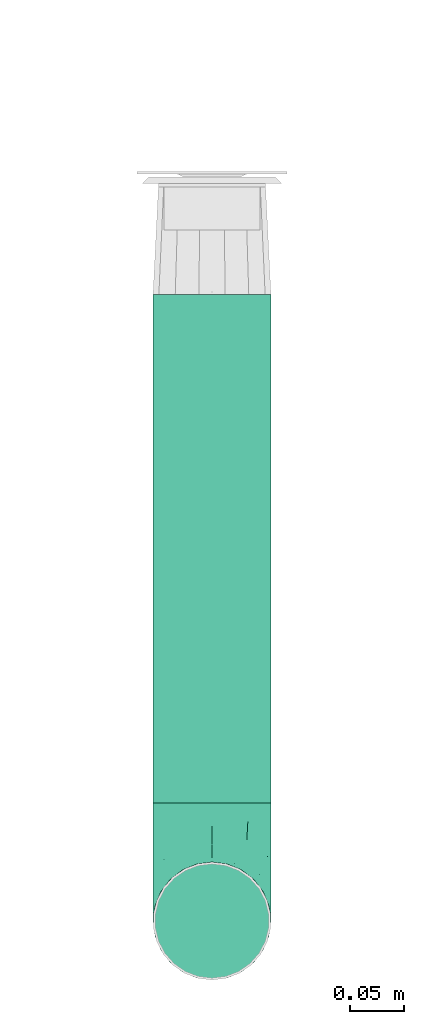
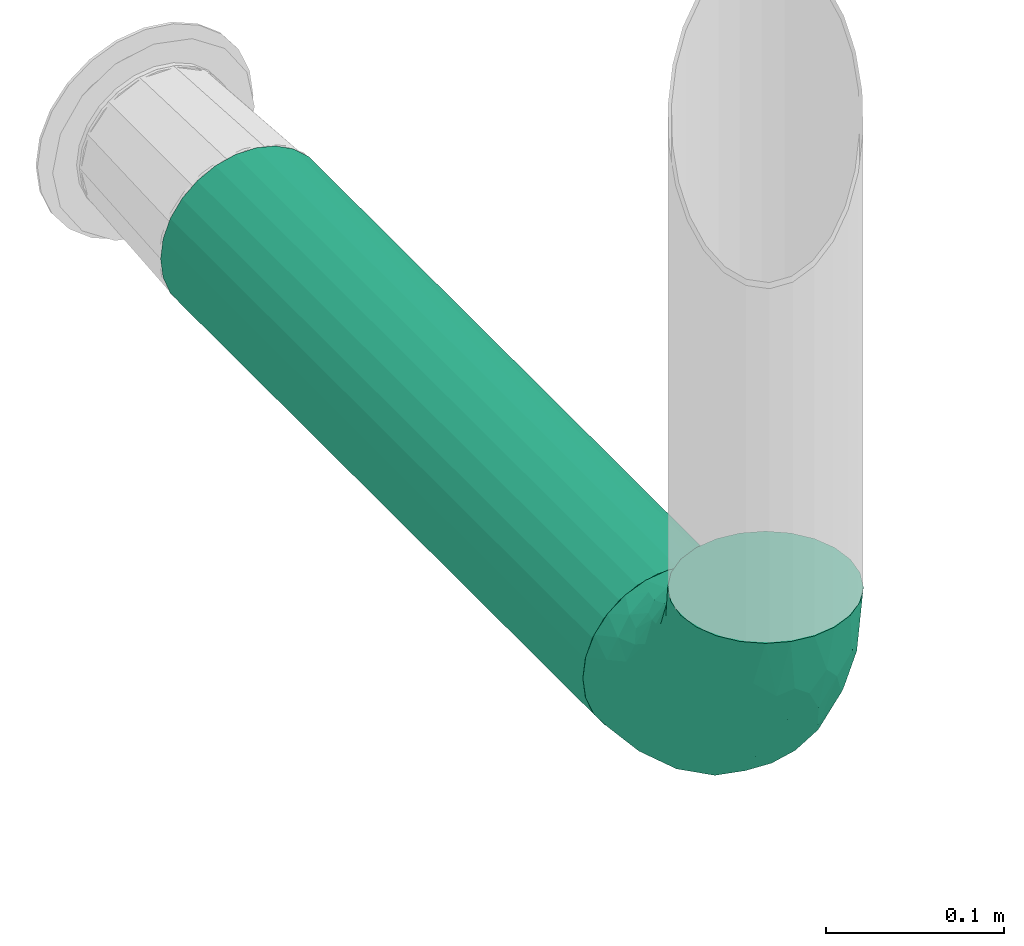
# One storey, part 56 of 115: 1 flow fitting, 1 flow segment.
"""IFC2X3 building model written with IfcOpenShell, lengths in millimetres."""

from ifc_helpers import new_model, entity, si_unit, converted_unit, derived_unit, direction, frame, origin_with_axes, origin_2d_with_axis, place, context, subcontext, project, spatial, hollow_circle, extrude, open_shell, surface_model, source, transform, mapped, material, layer, layer_set, layer_usage, type_object, element, save


model = new_model("IFC2X3")

# Units and contexts
model_context = context("Model", 3, precision=1e-05, world=origin_with_axes(), true_north=direction((0.0, 1.0)))
body_context = subcontext(model_context, "Body", "Model", "MODEL_VIEW")
ifc_project = project(units=[si_unit("AREAUNIT", "SQUARE_METRE"), si_unit("VOLUMEUNIT", "CUBIC_METRE", prefix="DECI"), si_unit("TIMEUNIT", "SECOND"), si_unit("THERMODYNAMICTEMPERATUREUNIT", "DEGREE_CELSIUS"), si_unit("PRESSUREUNIT", "PASCAL"), si_unit("MASSUNIT", "GRAM", prefix="KILO"), si_unit("LENGTHUNIT", "METRE", prefix="MILLI"), si_unit("POWERUNIT", "WATT"), si_unit("ELECTRICCURRENTUNIT", "AMPERE"), si_unit("ELECTRICVOLTAGEUNIT", "VOLT"), derived_unit("VOLUMETRICFLOWRATEUNIT", [(si_unit("VOLUMEUNIT", "CUBIC_METRE", prefix="DECI"), 1), (si_unit("TIMEUNIT", "SECOND"), -1)]), derived_unit("LINEARVELOCITYUNIT", [(si_unit("LENGTHUNIT", "METRE"), 1), (si_unit("TIMEUNIT", "SECOND"), -1)]), derived_unit("MASSDENSITYUNIT", [(si_unit("MASSUNIT", "GRAM", prefix="KILO"), 1), (si_unit("VOLUMEUNIT", "CUBIC_METRE"), -1)]), converted_unit("PLANEANGLEUNIT", "DEGREE", entity("IfcRatioMeasure", 0.01745), si_unit("PLANEANGLEUNIT", "RADIAN"), dimensions=[0, 0, 0, 0, 0, 0, 0])], contexts=[model_context])

# Site, building, storey
site_placement = place(None, origin_with_axes())
site = spatial("IfcSite", under=ifc_project, at=site_placement, CompositionType="ELEMENT")
building_placement = place(site_placement, origin_with_axes())
building = spatial("IfcBuilding", under=site, at=building_placement, Name="mc-building", CompositionType="ELEMENT")
storey_placement = place(building_placement, frame((0.0, 0.0, 2950.0), z_axis=(0.0, 0.0, 1.0), x_axis=(1.0, 0.0, 0.0)))
storey = spatial("IfcBuildingStorey", under=building, at=storey_placement, Name="2. Korrus", CompositionType="ELEMENT", Elevation=2950.0)

# Flow fitting
duct_fitting_type = type_object("IfcDuctFittingType", Name="BU", PredefinedType="BEND")
shared_shape_1 = source(origin_with_axes(), body_context, "Body", "SurfaceModel", [
    surface_model("IfcShellBasedSurfaceModel", [(-110.0, -38.89087, -38.89087), (-110.0, -55.0, 0.0), (-110.0, -27.5, -47.63139), (-110.0, -53.12592, -14.23505), (-110.0, -47.63139, -27.5), (-110.0, 47.63139, -27.5), (-110.0, 53.12592, 14.23505), (-110.0, 53.12592, -14.23505), (-110.0, -14.23505, -53.12592), (-110.0, 0.0, -55.0), (-110.0, 38.89087, -38.89087), (-110.0, 27.5, -47.63139), (-110.0, 14.23505, -53.12592), (-110.0, 55.0, 0.0), (-110.0, -53.12592, 14.23505), (-110.0, -47.63139, 27.5), (-110.0, -38.89087, 38.89087), (-110.0, 0.0, 55.0), (-110.0, -27.5, 47.63139), (-110.0, -14.23505, 53.12592), (-110.0, 38.89087, 38.89087), (-110.0, 47.63139, 27.5), (-110.0, 27.5, 47.63139), (-110.0, 14.23505, 53.12592), (0.0, -110.0, -55.0), (14.23505, -110.0, -53.12592), (-14.23505, -110.0, -53.12592), (-53.12592, -110.0, 14.23505), (-27.5, -110.0, -47.63139), (-47.63139, -110.0, -27.5), (-38.89087, -110.0, -38.89087), (55.0, -110.0, 0.0), (53.12592, -110.0, 14.23505), (38.89087, -110.0, -38.89087), (27.5, -110.0, -47.63139), (53.12592, -110.0, -14.23505), (47.63139, -110.0, -27.5), (-53.12592, -110.0, -14.23505), (-47.63139, -110.0, 27.5), (-38.89087, -110.0, 38.89087), (14.23505, -110.0, 53.12592), (-27.5, -110.0, 47.63139), (-14.23505, -110.0, 53.12592), (47.63139, -110.0, 27.5), (38.89087, -110.0, 38.89087), (27.5, -110.0, 47.63139), (0.0, -110.0, 55.0), (-55.0, -110.0, 0.0), (-60.44912, -32.56953, 51.94617), (-76.6405, -38.18013, 45.55988), (-64.21732, -48.68956, 43.63444), (-90.15553, -11.94394, 54.09138), (-76.00813, -5.38378, 55.0), (-70.18771, -18.55163, 54.03432), (-78.5998, -26.77405, 50.81338), (-93.27622, -45.77614, 33.48188), (-75.55424, -54.2118, 32.41257), (-96.12334, -22.13664, 50.81337), (-32.04182, -59.64019, 52.24446), (-18.36258, -70.48427, 54.04484), (-21.00813, -45.34362, 55.0), (-63.60674, -66.07878, 29.97482), (-74.66383, -63.08407, 19.92123), (-63.88653, -74.77858, 17.99134), (-93.11138, -56.59448, 10.50359), (-99.597, -52.72185, 18.52927), (-98.21577, -57.34403, 0.0), (-53.42855, -92.60092, 21.04759), (-88.54852, -54.8376, 21.04759), (-5.38378, -76.00813, 55.0), (-11.86161, -90.23965, 54.10313), (-56.64619, -93.12774, 10.22088), (-57.34403, -98.21577, 0.0), (-44.60838, -44.60838, 52.13415), (-45.34362, -21.00813, 55.0), (-92.68484, -35.46673, 43.63443), (-22.25266, -95.40765, 50.81337), (-27.23711, -77.39884, 50.81337), (-43.70931, -69.58671, 44.47149), (-35.97783, -90.61597, 43.63443), (-58.67786, -84.31125, 16.04456), (-57.2828, -79.3123, 24.9774), (-82.93277, -60.36161, 12.91784), (-49.88337, -54.51816, 47.224), (-74.57753, -66.83759, 9.55742), (-45.35812, -94.97281, 33.48188), (-59.18663, -88.95241, 0.0), (-51.517, -78.6292, 33.48188), (-65.14788, -80.03077, 0.0), (-56.45322, -62.06476, 39.63545), (-88.95241, -59.18663, 0.0), (-80.03077, -65.14788, 0.0), (-71.10913, -71.10913, 0.0), (-94.9309, -45.36788, -33.48188), (-93.11358, -56.60141, -10.46614), (-99.64997, -52.79499, -18.30015), (-79.99933, -46.56772, -37.92748), (-90.20425, -36.08686, -43.63443), (-45.34362, -21.00813, -55.0), (-72.75364, -19.68651, -53.60527), (-76.00813, -5.38378, -55.0), (-21.00813, -45.34362, -55.0), (-5.38378, -76.00813, -55.0), (-21.91957, -65.12078, -53.85897), (-35.41876, -92.89265, -43.63443), (-91.10309, -11.02766, -54.21832), (-45.77614, -93.27622, -33.48188), (-90.50474, -23.21022, -50.81337), (-70.92854, -33.31794, -49.51754), (-78.52933, -63.35627, -11.73997), (-24.91508, -84.05606, -50.81337), (-88.78941, -54.74452, -21.04759), (-63.49062, -67.59111, -28.46929), (-73.36422, -62.46673, -22.94182), (-69.59921, -57.34866, -33.48187), (-56.59448, -93.11138, -10.50359), (-54.10679, -75.85581, -32.31867), (-54.8376, -88.54852, -21.04759), (-57.75956, -31.09612, -52.80882), (-52.72185, -99.597, -18.52927), (-12.62913, -89.46304, -53.99097), (-34.46825, -66.46123, -50.04329), (-43.9837, -43.9837, -52.42279), (-65.78527, -72.58348, -17.68796), (-57.47001, -51.99467, -44.91465), (-70.34468, -43.65295, -44.21951), (-60.72547, -82.29174, -12.88567), (-42.34915, -74.24548, -43.63444), (-57.25194, -63.5016, -38.08211), (-80.95344, -53.56991, -29.32027), (-52.32891, -4.55257, -54.0482), (14.95561, -36.05775, -42.26543), (14.88266, -20.92917, -33.7947), (32.52942, -47.13398, -30.48571), (19.3559, -65.35825, -48.00507), (30.24048, -70.09027, -41.7461), (-28.49299, 30.5778, -16.4009), (-47.13398, 32.52942, -30.48571), (-70.35075, 46.44478, -19.5952), (-22.4954, -22.4954, -53.25347), (-4.55257, -52.32891, -54.0482), (-75.47368, 11.22546, -52.60718), (-81.32209, 51.5606, -9.98467), (-70.09027, 30.24048, -41.7461), (-80.81763, 41.84862, -32.14655), (-9.15831, 10.852, -27.8997), (-36.05774, 14.95561, -42.26543), (-65.35825, 19.3559, -48.00507), (3.94376, -43.9333, -50.53315), (11.22546, -75.47368, -52.60718), (-43.9333, 3.94376, -50.53315), (-13.39742, -13.39743, -48.13058), (50.20582, -74.51695, -9.9731), (41.8609, -47.82256, -9.92641), (49.37776, -67.29486, 0.0), (18.93131, -11.7156, -17.56239), (-1.23348, 12.25375, -12.18106), (-27.5, 32.89419, 0.0), (41.84862, -80.81763, -32.14655), (46.44478, -70.35075, -19.5952), (35.70604, -41.31408, -20.38235), (6.67262, 6.67262, 0.0), (32.89419, -27.5, 0.0), (-50.36265, 42.95545, -9.51562), (-67.29486, 49.37776, 0.0), (-5.47251, -5.47251, -39.92906), (-70.35075, 46.44478, 19.5952), (-74.51695, 50.20582, 9.9731), (-47.13398, 32.52942, 30.48571), (-41.31407, 35.70604, 20.38235), (-80.81763, 41.84862, 32.14655), (11.22546, -75.47368, 52.60718), (-4.55257, -52.32891, 54.0482), (-36.05774, 14.95561, 42.26543), (-65.35825, 19.3559, 48.00507), (-43.9333, 3.94376, 50.53315), (-70.09027, 30.24048, 41.7461), (-11.7156, 18.93131, 17.56239), (12.25375, -1.23348, 12.18106), (30.5778, -28.49299, 16.4009), (42.95545, -50.36265, 9.51562), (51.5606, -81.32209, 9.98467), (-52.32891, -4.55257, 54.0482), (-75.47368, 11.22546, 52.60718), (-13.39742, -13.39743, 48.13058), (-22.4954, -22.4954, 53.25347), (3.94376, -43.9333, 50.53315), (-20.92916, 14.88266, 33.79469), (10.852, -9.15831, 27.8997), (-47.82256, 41.8609, 9.92641), (32.52942, -47.13398, 30.48571), (46.44478, -70.35075, 19.5952), (41.84862, -80.81763, 32.14655), (14.95561, -36.05775, 42.26543), (19.3559, -65.35825, 48.00507), (30.24048, -70.09027, 41.7461), (-5.47251, -5.47251, 39.92906)], [open_shell([[[0, 1, 2]], [[3, 1, 4]], [[5, 6, 7]], [[8, 1, 9]], [[2, 1, 8]], [[4, 1, 0]], [[10, 9, 6]], [[9, 10, 11]], [[11, 12, 9]], [[6, 5, 10]], [[7, 6, 13]], [[14, 15, 9]], [[9, 15, 16]], [[17, 16, 18]], [[9, 16, 17]], [[19, 17, 18]], [[9, 20, 21]], [[6, 9, 21]], [[9, 22, 20]], [[23, 22, 9]], [[17, 23, 9]], [[9, 1, 14]], [[24, 25, 26]], [[26, 27, 28]], [[29, 30, 27]], [[28, 27, 30]], [[26, 31, 32]], [[33, 31, 34]], [[25, 34, 31]], [[35, 31, 36]], [[33, 36, 31]], [[31, 26, 25]], [[29, 27, 37]], [[38, 27, 26]], [[39, 38, 26]], [[40, 41, 26]], [[41, 39, 26]], [[40, 42, 41]], [[43, 44, 26]], [[43, 26, 32]], [[44, 45, 26]], [[26, 45, 40]], [[40, 46, 42]], [[47, 37, 27]], [[48, 49, 50]], [[51, 52, 17]], [[48, 53, 54]], [[49, 55, 56]], [[16, 15, 55]], [[18, 57, 19]], [[58, 59, 60]], [[61, 62, 63]], [[64, 65, 14]], [[53, 51, 54]], [[66, 64, 14]], [[27, 38, 67]], [[65, 68, 55]], [[68, 65, 64]], [[69, 59, 70]], [[71, 72, 27]], [[73, 60, 74]], [[55, 49, 75]], [[42, 70, 76]], [[51, 57, 54]], [[77, 78, 79]], [[42, 76, 41]], [[46, 70, 42]], [[55, 68, 56]], [[75, 18, 16]], [[77, 79, 76]], [[80, 67, 81]], [[68, 82, 62]], [[83, 78, 58]], [[82, 84, 62]], [[39, 79, 85]], [[71, 67, 80]], [[72, 71, 86]], [[67, 85, 87]], [[88, 80, 63]], [[39, 41, 79]], [[87, 79, 78]], [[55, 75, 16]], [[50, 89, 83]], [[38, 39, 85]], [[56, 68, 62]], [[61, 87, 89]], [[48, 50, 83]], [[18, 75, 57]], [[54, 75, 49]], [[38, 85, 67]], [[85, 79, 87]], [[56, 62, 61]], [[50, 56, 89]], [[87, 61, 81]], [[90, 64, 66]], [[14, 1, 66]], [[91, 92, 84]], [[82, 90, 91]], [[90, 82, 64]], [[62, 84, 63]], [[84, 82, 91]], [[64, 82, 68]], [[65, 15, 14]], [[15, 65, 55]], [[72, 47, 27]], [[86, 71, 80]], [[67, 71, 27]], [[88, 63, 92]], [[63, 80, 81]], [[63, 81, 61]], [[87, 81, 67]], [[41, 76, 79]], [[70, 59, 77]], [[76, 70, 77]], [[69, 70, 46]], [[77, 59, 58]], [[59, 69, 60]], [[77, 58, 78]], [[73, 58, 60]], [[19, 57, 51]], [[54, 57, 75]], [[19, 51, 17]], [[53, 52, 51]], [[53, 74, 52]], [[73, 74, 48]], [[53, 48, 74]], [[83, 73, 48]], [[73, 83, 58]], [[78, 83, 89]], [[78, 89, 87]], [[61, 89, 56]], [[54, 49, 48]], [[50, 49, 56]], [[88, 86, 80]], [[63, 84, 92]], [[93, 4, 0]], [[66, 94, 90]], [[95, 94, 3]], [[96, 93, 97]], [[98, 99, 100]], [[0, 2, 97]], [[101, 102, 103]], [[104, 28, 30]], [[9, 105, 8]], [[30, 106, 104]], [[107, 105, 99]], [[97, 107, 108]], [[94, 109, 90]], [[2, 8, 107]], [[94, 66, 3]], [[110, 26, 28]], [[94, 111, 109]], [[112, 113, 114]], [[72, 115, 37]], [[116, 106, 117]], [[98, 118, 99]], [[119, 115, 117]], [[115, 119, 37]], [[110, 120, 26]], [[103, 110, 121]], [[117, 106, 119]], [[120, 110, 103]], [[98, 101, 122]], [[117, 123, 116]], [[108, 124, 125]], [[126, 117, 115]], [[30, 29, 106]], [[120, 102, 24]], [[110, 104, 127]], [[97, 125, 96]], [[118, 122, 124]], [[124, 127, 128]], [[93, 0, 97]], [[86, 126, 115]], [[127, 106, 116]], [[129, 113, 111]], [[4, 93, 95]], [[114, 129, 96]], [[28, 104, 110]], [[127, 104, 106]], [[2, 107, 97]], [[108, 107, 99]], [[118, 108, 99]], [[100, 99, 105]], [[128, 112, 114]], [[127, 124, 121]], [[66, 1, 3]], [[91, 90, 109]], [[95, 111, 94]], [[109, 123, 92]], [[114, 113, 129]], [[111, 95, 93]], [[95, 3, 4]], [[86, 115, 72]], [[37, 47, 72]], [[88, 92, 123]], [[123, 117, 126]], [[126, 88, 123]], [[88, 126, 86]], [[119, 29, 37]], [[29, 119, 106]], [[111, 93, 129]], [[124, 114, 125]], [[100, 105, 9]], [[8, 105, 107]], [[108, 118, 124]], [[122, 118, 98]], [[96, 129, 93]], [[109, 111, 113]], [[113, 123, 109]], [[116, 123, 112]], [[113, 112, 123]], [[116, 112, 128]], [[116, 128, 127]], [[124, 128, 114]], [[103, 122, 101]], [[127, 121, 110]], [[121, 122, 103]], [[122, 121, 124]], [[26, 120, 24]], [[102, 120, 103]], [[108, 125, 97]], [[109, 92, 91]], [[96, 125, 114]], [[100, 130, 98]], [[131, 132, 133]], [[134, 135, 34]], [[136, 137, 138]], [[101, 139, 140]], [[9, 141, 100]], [[138, 7, 142]], [[137, 143, 144]], [[142, 7, 13]], [[145, 146, 137]], [[146, 147, 143]], [[5, 138, 144]], [[7, 138, 5]], [[5, 144, 10]], [[140, 148, 149]], [[143, 11, 10]], [[147, 12, 11]], [[100, 141, 130]], [[98, 139, 101]], [[148, 134, 149]], [[139, 150, 151]], [[152, 153, 154]], [[150, 139, 130]], [[25, 24, 149]], [[141, 12, 147]], [[132, 145, 155]], [[156, 136, 157]], [[158, 33, 135]], [[148, 139, 151]], [[36, 33, 158]], [[34, 135, 33]], [[159, 160, 153]], [[160, 159, 133]], [[137, 146, 143]], [[152, 154, 31]], [[137, 136, 145]], [[161, 162, 155]], [[133, 159, 158]], [[134, 148, 131]], [[163, 164, 157]], [[163, 142, 164]], [[102, 101, 140]], [[162, 154, 153]], [[159, 35, 36]], [[155, 156, 161]], [[131, 165, 132]], [[155, 145, 156]], [[98, 130, 139]], [[150, 130, 141]], [[147, 150, 141]], [[9, 12, 141]], [[149, 24, 102]], [[148, 140, 139]], [[140, 149, 102]], [[34, 25, 134]], [[146, 151, 150]], [[143, 147, 11]], [[147, 146, 150]], [[145, 165, 146]], [[25, 149, 134]], [[135, 134, 131]], [[135, 131, 133]], [[151, 165, 131]], [[148, 151, 131]], [[165, 151, 146]], [[160, 133, 132]], [[132, 165, 145]], [[36, 158, 159]], [[133, 158, 135]], [[10, 144, 143]], [[137, 144, 138]], [[162, 153, 155]], [[159, 153, 152]], [[160, 155, 153]], [[155, 160, 132]], [[152, 35, 159]], [[35, 152, 31]], [[136, 138, 163]], [[164, 142, 13]], [[142, 163, 138]], [[136, 163, 157]], [[161, 156, 157]], [[136, 156, 145]], [[166, 6, 21]], [[167, 164, 13]], [[166, 168, 169]], [[170, 168, 166]], [[69, 171, 172]], [[173, 174, 175]], [[174, 176, 22]], [[161, 157, 177]], [[170, 20, 176]], [[21, 20, 170]], [[178, 179, 162]], [[180, 181, 154]], [[182, 175, 183]], [[183, 23, 17]], [[184, 185, 186]], [[74, 185, 182]], [[52, 74, 182]], [[187, 188, 177]], [[166, 169, 189]], [[190, 179, 188]], [[22, 176, 20]], [[180, 154, 162]], [[32, 191, 43]], [[192, 44, 43]], [[43, 191, 192]], [[32, 31, 181]], [[193, 194, 195]], [[194, 40, 45]], [[190, 193, 195]], [[45, 44, 195]], [[69, 46, 171]], [[74, 60, 185]], [[157, 164, 189]], [[167, 189, 164]], [[172, 60, 69]], [[185, 172, 186]], [[173, 187, 168]], [[191, 32, 181]], [[190, 195, 192]], [[179, 190, 191]], [[175, 174, 183]], [[171, 40, 194]], [[188, 193, 190]], [[175, 185, 184]], [[177, 178, 161]], [[173, 196, 187]], [[177, 188, 178]], [[60, 172, 185]], [[186, 172, 171]], [[194, 186, 171]], [[46, 40, 171]], [[183, 17, 52]], [[175, 182, 185]], [[182, 183, 52]], [[22, 23, 174]], [[193, 184, 186]], [[195, 194, 45]], [[194, 193, 186]], [[188, 196, 193]], [[23, 183, 174]], [[176, 174, 173]], [[176, 173, 168]], [[184, 196, 173]], [[175, 184, 173]], [[196, 184, 193]], [[169, 168, 187]], [[187, 196, 188]], [[21, 170, 166]], [[168, 170, 176]], [[44, 192, 195]], [[190, 192, 191]], [[157, 189, 177]], [[166, 189, 167]], [[169, 177, 189]], [[177, 169, 187]], [[167, 6, 166]], [[6, 167, 13]], [[179, 191, 180]], [[154, 181, 31]], [[181, 180, 191]], [[179, 180, 162]], [[161, 178, 162]], [[179, 178, 188]]])]),
])
flow_fitting_placement = place(storey_placement, frame((19483.88525, -687.64676, 2300.0), z_axis=(1.0, 0.0, 0.0), x_axis=(0.0, -1.0, 0.0)))
element("IfcFlowFitting", 1, at=flow_fitting_placement, inside=storey, type_object=duct_fitting_type, Name="BU", context=body_context, shape_type="MappedRepresentation", body=[
    mapped(shared_shape_1, transform((0.0, 0.0, 0.0), scale=1.0)),
])

# Flow segment
ifc_material = material(Name="FZ1")
ifc_layer = layer(ifc_material, 0.0)
ifc_layer_set = layer_set([ifc_layer], Name="FZ1")
ifc_layer_usage = layer_usage(ifc_layer_set, "AXIS1", "POSITIVE", 0.0)
duct_segment_type = type_object("IfcDuctSegmentType", PredefinedType="RIGIDSEGMENT")
shared_shape_2 = source(origin_with_axes(), body_context, "Body", "SweptSolid", [
    extrude(hollow_circle(Radius=55.0, WallThickness=2.0, at=origin_2d_with_axis()), frame((0.0, 0.0, 0.0), z_axis=(1.0, 0.0, 0.0), x_axis=(0.0, 1.0, 0.0)), (0.0, 0.0, 1.0), 474.5),
])
flow_segment_placement = place(storey_placement, frame((19483.88525, -103.1, 2300.0), z_axis=(0.0, 0.0, 1.0), x_axis=(0.0, -1.0, 0.0)))
element("IfcFlowSegment", 2, at=flow_segment_placement, inside=storey, type_object=duct_segment_type, material=ifc_layer_usage, context=body_context, shape_type="MappedRepresentation", body=[
    mapped(shared_shape_2, transform((0.0, 0.0, 0.0), scale=1.0)),
])

save(model, "model.ifc")
